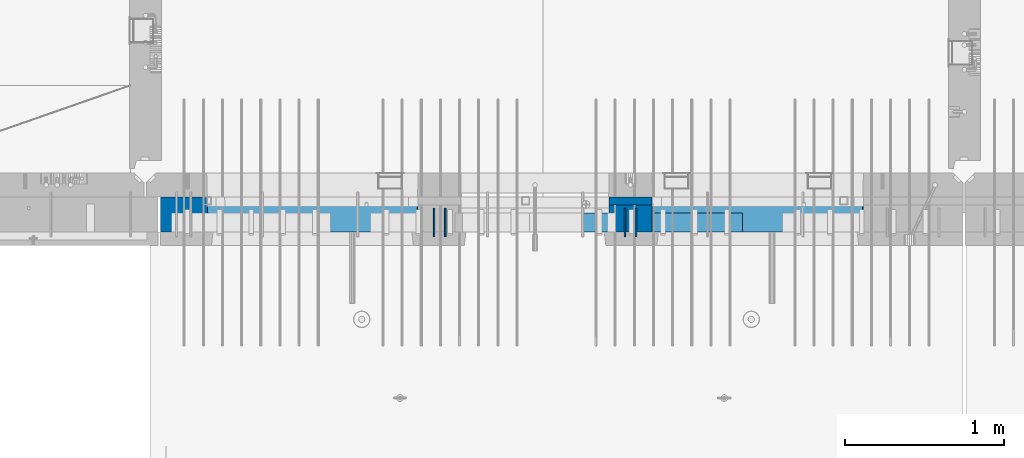
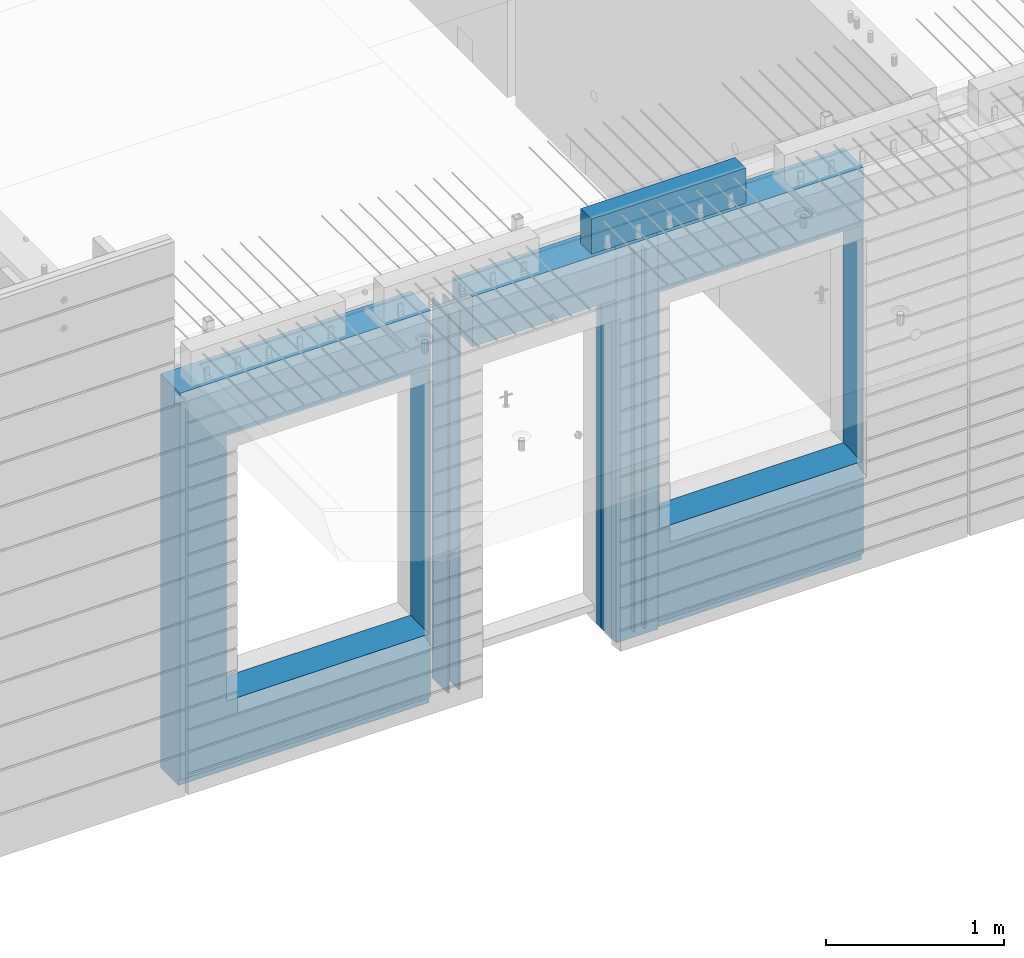
# One storey, part 195 of 309: 8 walls, 3 elements without a shape of their own.
"""IFC2X3 building model written with IfcOpenShell, lengths in millimetres."""

from ifc_helpers import new_model, si_unit, frame, origin_with_axes, place, context, subcontext, project, spatial, faceted_brep, material, type_object, element, aggregate, save


model = new_model("IFC2X3")

# Units and contexts
model_context = context("Model", 3, precision=1e-05, world=origin_with_axes())
body_context = subcontext(model_context, "Body", "Model", "MODEL_VIEW")
ifc_project = project(units=[si_unit("LENGTHUNIT", "METRE", prefix="MILLI"), si_unit("AREAUNIT", "SQUARE_METRE"), si_unit("VOLUMEUNIT", "CUBIC_METRE"), si_unit("MASSUNIT", "GRAM", prefix="KILO"), si_unit("TIMEUNIT", "SECOND"), si_unit("PLANEANGLEUNIT", "RADIAN"), si_unit("SOLIDANGLEUNIT", "STERADIAN"), si_unit("THERMODYNAMICTEMPERATUREUNIT", "DEGREE_CELSIUS"), si_unit("LUMINOUSINTENSITYUNIT", "LUMEN")], contexts=[model_context])

# Site, building, storey
site_placement = place(None, origin_with_axes())
site = spatial("IfcSite", under=ifc_project, at=site_placement, CompositionType="ELEMENT")
building_placement = place(site_placement, origin_with_axes())
building = spatial("IfcBuilding", under=site, at=building_placement, CompositionType="ELEMENT")
storey_placement = place(building_placement, origin_with_axes())
storey = spatial("IfcBuildingStorey", under=building, at=storey_placement, Name="7", CompositionType="ELEMENT", Elevation=0.0)

# Assembly, walls
assembly_1_placement = place(storey_placement, origin_with_axes())
assembly_1 = element("IfcElementAssembly", 1, at=assembly_1_placement, inside=storey, AssemblyPlace="NOTDEFINED", PredefinedType="REINFORCEMENT_UNIT")
ifc_material_1 = material(Name="Undefined")
wall_type_1 = type_object("IfcWallType", PredefinedType="NOTDEFINED")
wall_1_placement = place(assembly_1_placement, frame((18475.0, 7780.0, 101115.0), z_axis=(0.0, 0.0, 1.0), x_axis=(0.0, -1.0, 0.0)))
wall_1 = element("IfcWall", 2, at=wall_1_placement, type_object=wall_type_1, material=ifc_material_1, Name="(PD)", context=body_context, shape_type="Brep", body=[
    faceted_brep([(0.0, 5.0, -1300.0), (0.0, 5.0, 1300.0), (180.0, 5.0, 1300.0), (180.0, 5.0, -1300.0), (0.0, -5.0, 1300.0), (180.0, -5.0, 1300.0), (0.0, -5.0, -1300.0), (180.0, -5.0, -1300.0)], [[[0, 1, 2, 3]], [[1, 4, 5, 2]], [[4, 6, 7, 5]], [[6, 0, 3, 7]], [[5, 7, 3, 2]], [[6, 4, 1, 0]]]),
])
wall_2_placement = place(assembly_1_placement, frame((18545.0, 7780.0, 101115.0), z_axis=(0.0, 0.0, 1.0), x_axis=(0.0, -1.0, 0.0)))
wall_2 = element("IfcWall", 3, at=wall_2_placement, type_object=wall_type_1, material=ifc_material_1, Name="(PD)", context=body_context, shape_type="Brep", body=[
    faceted_brep([(0.0, 5.0, -1300.0), (0.0, 5.0, 1300.0), (180.0, 5.0, 1300.0), (180.0, 5.0, -1300.0), (0.0, -5.0, 1300.0), (180.0, -5.0, 1300.0), (0.0, -5.0, -1300.0), (180.0, -5.0, -1300.0)], [[[0, 1, 2, 3]], [[1, 4, 5, 2]], [[4, 6, 7, 5]], [[6, 0, 3, 7]], [[5, 7, 3, 2]], [[6, 4, 1, 0]]]),
])
wall_3_placement = place(assembly_1_placement, frame((19675.0, 7779.99999999997, 101115.0), z_axis=(0.0, 0.0, 1.0), x_axis=(0.0, -1.0, 0.0)))
wall_3 = element("IfcWall", 4, at=wall_3_placement, type_object=wall_type_1, material=ifc_material_1, Name="(PD)", context=body_context, shape_type="Brep", body=[
    faceted_brep([(0.0, 5.0, -1300.0), (0.0, 5.0, 1300.0), (180.0, 5.0, 1300.0), (180.0, 5.0, -1300.0), (0.0, -5.0, 1300.0), (180.0, -5.0, 1300.0), (0.0, -5.0, -1300.0), (180.0, -5.0, -1300.0)], [[[0, 1, 2, 3]], [[1, 4, 5, 2]], [[4, 6, 7, 5]], [[6, 0, 3, 7]], [[5, 7, 3, 2]], [[6, 4, 1, 0]]]),
])
wall_4_placement = place(assembly_1_placement, frame((19745.0, 7780.0, 101115.0), z_axis=(0.0, 0.0, 1.0), x_axis=(0.0, -1.0, 0.0)))
wall_4 = element("IfcWall", 5, at=wall_4_placement, type_object=wall_type_1, material=ifc_material_1, Name="(PD)", context=body_context, shape_type="Brep", body=[
    faceted_brep([(0.0, 5.0, -1300.0), (0.0, 5.0, 1300.0), (180.0, 5.0, 1300.0), (180.0, 5.0, -1300.0), (0.0, -5.0, 1300.0), (180.0, -5.0, 1300.0), (0.0, -5.0, -1300.0), (180.0, -5.0, -1300.0)], [[[0, 1, 2, 3]], [[1, 4, 5, 2]], [[4, 6, 7, 5]], [[6, 0, 3, 7]], [[5, 7, 3, 2]], [[6, 4, 1, 0]]]),
])

# Assemblies, wall
assembly_2_placement = place(storey_placement, origin_with_axes())
assembly_2 = element("IfcElementAssembly", 6, at=assembly_2_placement, inside=storey, AssemblyPlace="NOTDEFINED", PredefinedType="REINFORCEMENT_UNIT")
assembly_3_placement = place(assembly_2_placement, origin_with_axes())
assembly_3 = element("IfcElementAssembly", 7, at=assembly_3_placement, Name="Steel Assembly", AssemblyPlace="NOTDEFINED", PredefinedType="NOTDEFINED")
aggregate(assembly_2, [assembly_3])
ifc_material_2 = material()
wall_type_2 = type_object("IfcWallType", PredefinedType="NOTDEFINED")
wall_5_placement = place(assembly_3_placement, frame((19414.9998568133, 7690.00021946163, 102590.0), z_axis=(0.0, 0.0, 1.0), x_axis=(1.0, 0.0, 0.0)))
wall_5 = element("IfcWall", 8, at=wall_5_placement, type_object=wall_type_2, material=ifc_material_2, context=body_context, shape_type="Brep", body=[
    faceted_brep([(0.0, 60.0, -120.0), (0.0, 60.0, 120.0), (1000.0, 60.0, 120.0), (1000.0, 60.0, -120.0), (0.0, -60.0, 120.0), (1000.0, -60.0, 120.0), (0.0, -60.0, -120.0), (1000.0, -60.0, -120.0)], [[[0, 1, 2, 3]], [[1, 4, 5, 2]], [[4, 6, 7, 5]], [[6, 0, 3, 7]], [[5, 7, 3, 2]], [[6, 4, 1, 0]]]),
])
aggregate(assembly_3, [wall_5])

# Wall
ifc_material_3 = material(Name="CONCRETE/C35/45")
wall_type_3 = type_object("IfcWallType", PredefinedType="NOTDEFINED")
wall_6_placement = place(assembly_1_placement, frame((19845.0100381475, 7825.0, 101112.5), z_axis=(0.0, 0.0, 1.0), x_axis=(-1.0, 3.00000001838171e-08, 0.0)))
wall_6 = element("IfcWall", 9, at=wall_6_placement, type_object=wall_type_3, material=ifc_material_3, context=body_context, shape_type="Brep", body=[
    faceted_brep([(0.0, 25.0, -1357.5), (0.0, 25.0, 1357.5), (270.001908754726, 25.0, 1357.5), (270.001908754726, 25.0, -1357.5), (0.0, -25.0, 1357.5), (270.001908754726, -25.0, 1357.5), (0.0, -25.0, -1357.5), (270.001908754726, -25.0, -1357.5)], [[[0, 1, 2, 3]], [[1, 4, 5, 2]], [[4, 6, 7, 5]], [[6, 0, 3, 7]], [[5, 7, 3, 2]], [[6, 4, 1, 0]]]),
])

ifc_material_4 = material(Name="SPU")
wall_type_4 = type_object("IfcWallType", PredefinedType="NOTDEFINED")
wall_7_placement = place(assembly_1_placement, frame((19845.0100381475, 7715.0, 101102.5), z_axis=(0.0, 0.0, 1.0), x_axis=(-1.0, 3.00000001838171e-08, 0.0)))
wall_7 = element("IfcWall", 10, at=wall_7_placement, type_object=wall_type_4, material=ifc_material_4, context=body_context, shape_type="Brep", body=[
    faceted_brep([(0.0, 85.0, -1347.5), (0.0, 85.0, 1347.5), (270.001908754726, 85.0, 1347.5), (270.001908754726, 85.0, -1347.5), (0.0, -85.0, 1347.5), (270.001908754726, -85.0, 1347.5), (0.0, -85.0, -1347.5), (270.001908754726, -85.0, -1347.5)], [[[0, 1, 2, 3]], [[1, 4, 5, 2]], [[4, 6, 7, 5]], [[6, 0, 3, 7]], [[5, 7, 3, 2]], [[6, 4, 1, 0]]]),
])

ifc_material_5 = material(Name="COS5gt")
wall_type_5 = type_object("IfcWallType", PredefinedType="NOTDEFINED")
wall_8_placement = place(assembly_1_placement, frame((21175.0, 7740.0, 101102.5), z_axis=(0.0, 0.0, 1.0), x_axis=(-1.0, 3.00000001838171e-08, 0.0)))
wall_8 = element("IfcWall", 11, at=wall_8_placement, type_object=wall_type_5, material=ifc_material_5, context=body_context, shape_type="Brep", body=[
    faceted_brep([(4420.0, -110.0, 1347.5), (4420.0, 110.0, 1347.5), (2799.99187060721, 110.0, 1347.5), (2799.99187060721, -10.0, 1347.5), (2799.9818706072, -110.0, 1347.5), (4420.0, 110.0, -1297.5), (4420.0, 90.0, -1297.5), (2799.99187060721, 90.0, -1297.5), (2799.99187060721, 110.0, -1297.5), (4420.0, -110.0, -1347.5), (4420.0, 90.0, -1347.5), (2799.99187060721, 90.0, -1347.5), (2799.99187060721, -10.0, -1347.5), (2809.99937278789, 110.0, -862.5), (2839.99937278789, 110.0, -862.5), (4089.99937278789, 110.0, -862.5), (4119.99937278789, 110.0, -862.5), (4119.99937278789, 110.0, -857.5), (4119.99937278789, 110.0, 952.5), (2809.99937278789, 110.0, 952.5), (2809.99937278789, 110.0, -857.5), (2804.05342684194, -110.0, -868.445945945947), (2804.05342684194, -109.999999999999, 958.445945945947), (4125.94531873383, -110.0, -868.445945945947), (4125.94531873383, -109.999999999999, 958.445945945947), (2799.9818706072, -110.0, -1347.5), (1329.98996185248, -110.0, 1347.5), (1329.98996185248, -110.0, -1347.5), (1329.98996185248, -10.0, -1347.5), (1329.98996185248, -10.0, 1347.5), (0.0, -110.0, -1347.5), (0.0, 90.0, -1347.5), (1329.98996185248, 90.0, -1347.5), (0.0, 90.0, -1297.5), (0.0, 110.0, -1297.5), (1329.98996185248, 110.0, -1297.5), (1329.98996185248, 90.0, -1297.5), (0.0, -110.0, 1347.5), (0.0, 110.0, 1347.5), (1329.98996185248, 110.0, 1347.5), (10.0001357273395, 110.0, -662.5), (40.0001357273395, 110.0, -662.5), (1290.00013572734, 110.0, -662.5), (1320.00013572734, 110.0, -662.5), (1320.00013572734, 110.0, -657.5), (1320.00013572734, 110.0, 952.5), (10.0001357273395, 110.0, 952.5), (10.0001357273395, 110.0, -657.5), (4.05418978139278, -110.0, -668.445945945947), (4.05418978139278, -109.999999999999, 958.445945945947), (1325.94608167329, -110.0, -668.445945945947), (1325.94608167329, -109.999999999999, 958.445945945947), (1600.00051719707, -109.999999999999, 1002.5), (1599.99187060721, -110.0, 1347.5), (1599.99187060721, -10.0, 1347.5), (1600.00051719707, -10.0, 1002.5), (1600.00051719707, 110.0, 1002.5), (1599.99187060721, 110.0, 1347.5), (2529.98996185248, 110.0, 1347.5), (2529.98996185248, 110.0, 1002.5), (2529.98996185248, -10.0, 1347.5), (2529.98996185248, -10.0, 1002.5), (2529.97996185248, -110.0, 1347.5), (2529.97996185248, -109.999999999999, 1002.5)], [[[0, 1, 2, 3, 4]], [[5, 6, 7, 8]], [[1, 0, 9, 10, 6, 5]], [[6, 10, 11, 7]], [[2, 8, 7, 11, 12, 3]], [[1, 5, 8, 2], [13, 14, 15, 16, 17, 18, 19, 20]], [[21, 13, 20, 19, 22]], [[23, 16, 15, 14, 13, 21]], [[17, 16, 23, 24, 18]], [[22, 19, 18, 24]], [[9, 0, 4, 25], [23, 21, 22, 24]], [[11, 10, 9, 25, 12]], [[4, 3, 12, 25]], [[26, 27, 28, 29]], [[27, 30, 31, 32, 28]], [[33, 34, 35, 36]], [[31, 33, 36, 32]], [[30, 37, 38, 34, 33, 31]], [[38, 37, 26, 29, 39]], [[29, 28, 32, 36, 35, 39]], [[34, 38, 39, 35], [40, 41, 42, 43, 44, 45, 46, 47]], [[48, 40, 47, 46, 49]], [[50, 43, 42, 41, 40, 48]], [[44, 43, 50, 51, 45]], [[49, 46, 45, 51]], [[37, 30, 27, 26], [50, 48, 49, 51]], [[52, 53, 54, 55]], [[56, 57, 58, 59]], [[59, 58, 60, 61]], [[62, 63, 61, 60]], [[53, 52, 63, 62]], [[56, 59, 61, 63, 52, 55]], [[54, 57, 56, 55]], [[62, 60, 58, 57, 54, 53]]]),
])

aggregate(assembly_1, [wall_7, wall_1, wall_2, wall_6, wall_3, wall_4, wall_8])

save(model, "model.ifc")
